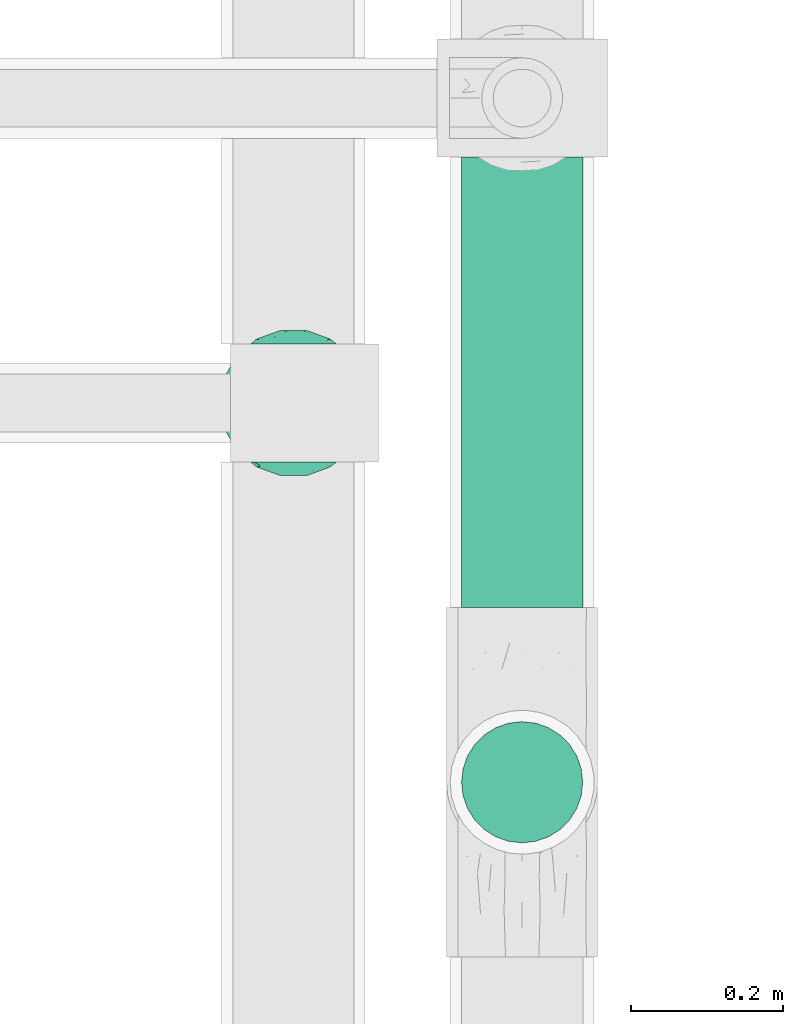
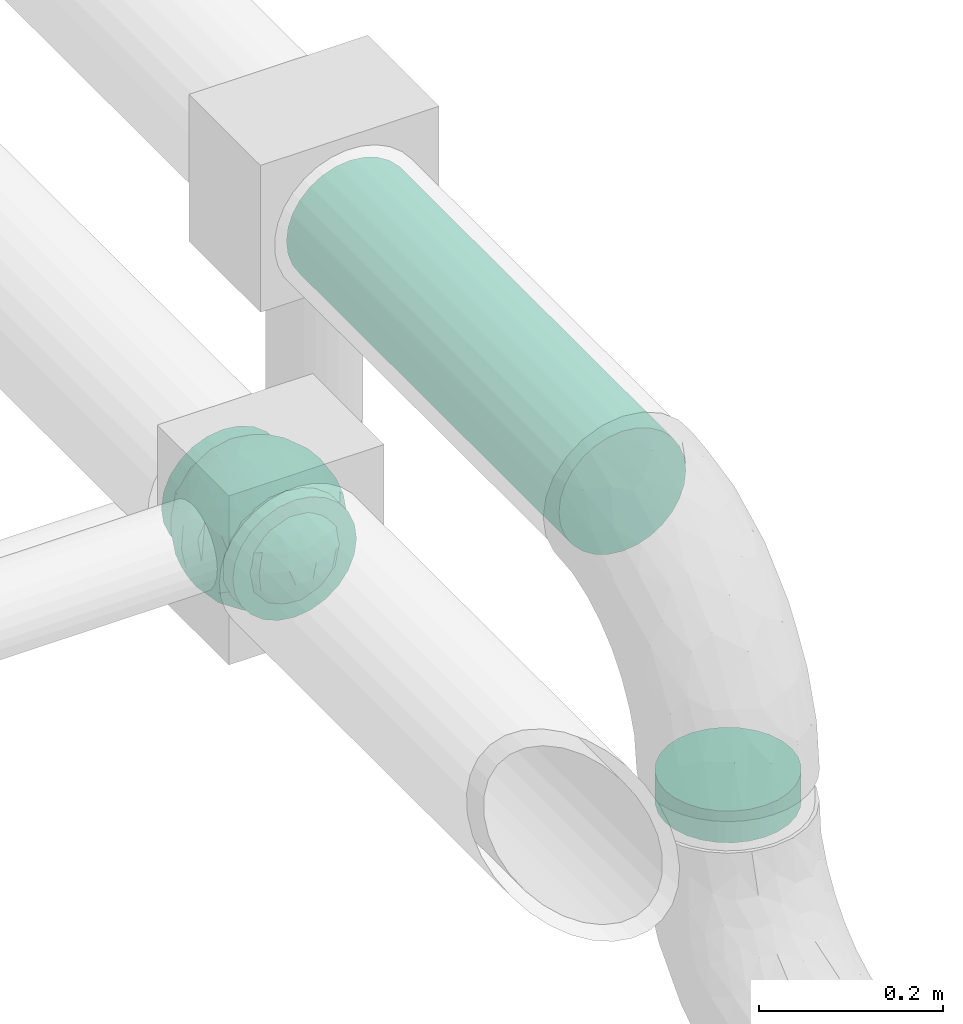
# One storey, part 609 of 827: 2 flow segments, 1 flow fitting.
"""IFC2X3 building model written with IfcOpenShell, lengths in millimetres."""

from ifc_helpers import new_model, entity, si_unit, converted_unit, derived_unit, direction, frame, origin, origin_2d_with_axis, place, context, subcontext, project, spatial, circle, extrude, faceted_brep, source, transform, mapped, material, material_list, type_object, type_shapes, element, save


model = new_model("IFC2X3")

# Units and contexts
model_context = context("Model", 3, precision=0.01, world=origin(), true_north=direction((6.12303176911189e-17, 1.0)))
body_context = subcontext(model_context, "Body", "Model", "MODEL_VIEW")
ifc_project = project(units=[si_unit("LENGTHUNIT", "METRE", prefix="MILLI"), si_unit("AREAUNIT", "SQUARE_METRE"), si_unit("VOLUMEUNIT", "CUBIC_METRE"), converted_unit("PLANEANGLEUNIT", "DEGREE", entity("IfcRatioMeasure", 0.0174532925199433), si_unit("PLANEANGLEUNIT", "RADIAN"), dimensions=[0, 0, 0, 0, 0, 0, 0]), si_unit("MASSUNIT", "GRAM", prefix="KILO"), derived_unit("MASSDENSITYUNIT", [(si_unit("MASSUNIT", "GRAM", prefix="KILO"), 1), (si_unit("LENGTHUNIT", "METRE"), -3)]), derived_unit("MOMENTOFINERTIAUNIT", [(si_unit("LENGTHUNIT", "METRE"), 4)]), si_unit("TIMEUNIT", "SECOND"), si_unit("FREQUENCYUNIT", "HERTZ"), si_unit("THERMODYNAMICTEMPERATUREUNIT", "DEGREE_CELSIUS"), derived_unit("THERMALTRANSMITTANCEUNIT", [(si_unit("MASSUNIT", "GRAM", prefix="KILO"), 1), (si_unit("THERMODYNAMICTEMPERATUREUNIT", "KELVIN"), -1), (si_unit("TIMEUNIT", "SECOND"), -3)]), derived_unit("VOLUMETRICFLOWRATEUNIT", [(si_unit("LENGTHUNIT", "METRE"), 3), (si_unit("TIMEUNIT", "SECOND"), -1)]), derived_unit("MASSFLOWRATEUNIT", [(si_unit("MASSUNIT", "GRAM", prefix="KILO"), 1), (si_unit("TIMEUNIT", "SECOND"), -1)]), derived_unit("ROTATIONALFREQUENCYUNIT", [(si_unit("TIMEUNIT", "SECOND"), -1)]), si_unit("ELECTRICCURRENTUNIT", "AMPERE"), si_unit("ELECTRICVOLTAGEUNIT", "VOLT"), si_unit("POWERUNIT", "WATT"), si_unit("FORCEUNIT", "NEWTON", prefix="KILO"), si_unit("ILLUMINANCEUNIT", "LUX"), si_unit("LUMINOUSFLUXUNIT", "LUMEN"), si_unit("LUMINOUSINTENSITYUNIT", "CANDELA"), derived_unit("USERDEFINED", [(si_unit("MASSUNIT", "GRAM", prefix="KILO"), -1), (si_unit("LENGTHUNIT", "METRE"), -2), (si_unit("TIMEUNIT", "SECOND"), 3), (si_unit("LUMINOUSFLUXUNIT", "LUMEN"), 1)]), derived_unit("LINEARVELOCITYUNIT", [(si_unit("LENGTHUNIT", "METRE"), 1), (si_unit("TIMEUNIT", "SECOND"), -1)]), si_unit("PRESSUREUNIT", "PASCAL"), derived_unit("USERDEFINED", [(si_unit("LENGTHUNIT", "METRE"), -2), (si_unit("MASSUNIT", "GRAM", prefix="KILO"), 1), (si_unit("TIMEUNIT", "SECOND"), -2)]), derived_unit("LINEARFORCEUNIT", [(si_unit("MASSUNIT", "GRAM", prefix="KILO"), 1), (si_unit("LENGTHUNIT", "METRE"), 1), (si_unit("TIMEUNIT", "SECOND"), -2), (si_unit("LENGTHUNIT", "METRE"), -1)]), derived_unit("PLANARFORCEUNIT", [(si_unit("MASSUNIT", "GRAM", prefix="KILO"), 1), (si_unit("LENGTHUNIT", "METRE"), 1), (si_unit("TIMEUNIT", "SECOND"), -2), (si_unit("LENGTHUNIT", "METRE"), -2)])], contexts=[model_context])

# Site, building, storey
site_placement = place(None, origin())
site = spatial("IfcSite", under=ifc_project, at=site_placement, CompositionType="ELEMENT")
building_placement = place(site_placement, origin())
building = spatial("IfcBuilding", under=site, at=building_placement, CompositionType="ELEMENT")
storey_placement = place(building_placement, frame((0.0, 0.0, 28200.0)))
storey = spatial("IfcBuildingStorey", under=building, at=storey_placement, Name="08", CompositionType="ELEMENT", Elevation=28200.0)

# Flow segments
pipe_segment_type = type_object("IfcPipeSegmentType", PredefinedType="NOTDEFINED")
flow_segment_1_placement = place(storey_placement, frame((37967.2, 9811.72, 2918.9)))
element("IfcFlowSegment", 1, at=flow_segment_1_placement, inside=storey, type_object=pipe_segment_type, context=body_context, shape_type="SweptSolid", body=[
    extrude(circle(Radius=79.5, at=origin_2d_with_axis()), frame((81.1, 0.0, 81.1), z_axis=(0.0, 1.0, 0.0), x_axis=(-1.0, 0.0, 0.0)), (0.0, 0.0, 1.0), 590.986619555691),
])
flow_segment_2_placement = place(storey_placement, frame((37967.2, 9501.62, 2729.0)))
element("IfcFlowSegment", 2, at=flow_segment_2_placement, inside=storey, type_object=pipe_segment_type, context=body_context, shape_type="SweptSolid", body=[
    extrude(circle(Radius=79.5, at=origin_2d_with_axis()), frame((81.1, 81.1, 0.0)), (0.0, 0.0, 1.0), 42.0000000000208),
])

# Flow fitting
ifc_material_1 = material()
ifc_material_2 = material(Name="ADSK_")
ifc_material_list = material_list([ifc_material_1, ifc_material_2])
pipe_fitting_type = type_object("IfcPipeFittingType", Name="ADSK_1", PredefinedType="NOTDEFINED", material=ifc_material_list)
shared_shape = source(origin(), body_context, "Body", "Brep", [
    faceted_brep([(-77.5, 38.75, -67.12), (-77.5, 20.06, -74.86), (-77.5, 0.0, -77.5), (-77.5, -20.06, -74.86), (-77.5, -38.75, -67.12), (-77.5, -54.8, -54.8), (-77.5, -67.12, -38.75), (-77.5, -74.86, -20.06), (-77.5, -76.18, -10.03), (-77.5, -77.5, 0.0), (-77.5, -76.18, 10.03), (-77.5, -74.86, 20.06), (-77.5, -67.12, 38.75), (-77.5, -54.8, 54.8), (-77.5, -38.75, 67.12), (-77.5, -20.06, 74.86), (-77.5, 0.0, 77.5), (-77.5, 20.06, 74.86), (-77.5, 38.75, 67.12), (-77.5, 54.8, 54.8), (-77.5, 67.12, 38.75), (-77.5, 74.86, 20.06), (-77.5, 77.5, 0.0), (-77.5, 74.86, -20.06), (-77.5, 67.12, -38.75), (-77.5, 54.8, -54.8), (77.5, 0.0, -77.5), (77.5, 20.06, -74.86), (77.5, 38.75, -67.12), (77.5, 54.8, -54.8), (77.5, 67.12, -38.75), (77.5, 74.86, -20.06), (77.5, 77.5, 0.0), (77.5, 74.86, 20.06), (77.5, 67.12, 38.75), (77.5, 54.8, 54.8), (77.5, 38.75, 67.12), (77.5, 20.06, 74.86), (77.5, 0.0, 77.5), (77.5, -20.06, 74.86), (77.5, -38.75, 67.12), (77.5, -54.8, 54.8), (77.5, -67.12, 38.75), (77.5, -74.86, 20.06), (77.5, -76.18, 10.03), (77.5, -77.5, 0.0), (77.5, -76.18, -10.03), (77.5, -74.86, -20.06), (77.5, -67.12, -38.75), (77.5, -54.8, -54.8), (77.5, -38.75, -67.12), (77.5, -20.06, -74.86), (32.85, -76.55, 12.09), (35.0, -77.5, 0.0), (-35.0, -77.5, 0.0), (26.77, -74.15, 22.55), (6.15, -69.42, 34.46), (17.58, -71.35, 30.26), (11.87, -70.38, 32.36), (-32.85, -76.55, 12.09), (-33.92, -77.03, 6.04), (-26.78, -74.15, 22.54), (-17.59, -71.35, 30.26), (-11.87, -70.38, 32.36), (-6.16, -69.42, 34.45), (0.0, -69.42, 34.45), (33.92, -77.03, 6.04), (6.15, -69.42, -34.46), (-32.85, -76.55, -12.09), (-33.92, -77.03, -6.04), (17.58, -71.35, -30.26), (11.87, -70.38, -32.36), (32.85, -76.55, -12.09), (26.77, -74.15, -22.55), (33.92, -77.03, -6.04), (-6.16, -69.42, -34.45), (-11.87, -70.38, -32.36), (-17.59, -71.35, -30.26), (0.0, -69.42, -34.45), (-26.78, -74.15, -22.54), (0.0, -82.5, -35.0), (9.06, -82.5, -33.81), (17.5, -82.5, -30.31), (24.75, -82.5, -24.75), (30.31, -82.5, -17.5), (33.81, -82.5, -9.06), (35.0, -82.5, 0.0), (33.81, -82.5, 9.06), (30.31, -82.5, 17.5), (24.75, -82.5, 24.75), (17.5, -82.5, 30.31), (9.06, -82.5, 33.81), (0.0, -82.5, 35.0), (-9.06, -82.5, 33.81), (-17.5, -82.5, 30.31), (-24.75, -82.5, 24.75), (-30.31, -82.5, 17.5), (-33.81, -82.5, 9.06), (-35.0, -82.5, 0.0), (-33.81, -82.5, -9.06), (-30.31, -82.5, -17.5), (-24.75, -82.5, -24.75), (-17.5, -82.5, -30.31), (-9.06, -82.5, -33.81)], [[[0, 1, 2, 3, 4, 5, 6, 7, 8, 9, 10, 11, 12, 13, 14, 15, 16, 17, 18, 19, 20, 21, 22, 23, 24, 25]], [[26, 27, 28, 29, 30, 31, 32, 33, 34, 35, 36, 37, 38, 39, 40, 41, 42, 43, 44, 45, 46, 47, 48, 49, 50, 51]], [[44, 43, 52]], [[53, 45, 44]], [[9, 54, 10]], [[43, 55, 52]], [[42, 41, 56]], [[55, 43, 57]], [[42, 56, 58, 57]], [[41, 13, 56]], [[57, 43, 42]], [[59, 11, 10]], [[10, 54, 60, 59]], [[59, 61, 11]], [[12, 62, 63, 64]], [[12, 11, 62]], [[12, 64, 13]], [[62, 11, 61]], [[13, 64, 65, 56]], [[44, 52, 66, 53]], [[41, 40, 14, 13]], [[16, 15, 39, 38]], [[15, 14, 40, 39]], [[17, 16, 38, 37]], [[34, 33, 21, 20]], [[19, 18, 36, 35]], [[20, 19, 35, 34]], [[37, 36, 18, 17]], [[22, 21, 33, 32]], [[24, 23, 31, 30]], [[23, 22, 32, 31]], [[25, 24, 30, 29]], [[26, 51, 3, 2]], [[1, 0, 28, 27]], [[2, 1, 27, 26]], [[29, 28, 0, 25]], [[4, 3, 51, 50]], [[50, 49, 5, 4]], [[49, 48, 67]], [[8, 68, 69, 54]], [[48, 70, 71, 67]], [[48, 47, 70]], [[49, 67, 5]], [[45, 53, 46]], [[8, 54, 9]], [[72, 73, 47]], [[46, 53, 74, 72]], [[47, 73, 70]], [[6, 75, 76, 77]], [[72, 47, 46]], [[6, 5, 75]], [[77, 7, 6]], [[5, 67, 78, 75]], [[79, 68, 7]], [[68, 8, 7]], [[79, 7, 77]], [[80, 81, 82, 83, 84, 85, 86, 87, 88, 89, 90, 91, 92, 93, 94, 95, 96, 97, 98, 99, 100, 101, 102, 103]], [[98, 97, 60]], [[61, 96, 95]], [[97, 96, 59]], [[95, 94, 62]], [[86, 66, 87]], [[98, 60, 54]], [[59, 96, 61]], [[93, 64, 63]], [[63, 62, 94]], [[62, 61, 95]], [[92, 56, 65, 64]], [[93, 63, 94]], [[58, 56, 91]], [[56, 92, 91]], [[92, 64, 93]], [[55, 89, 88]], [[90, 89, 57]], [[52, 88, 87]], [[90, 58, 91]], [[89, 55, 57]], [[58, 90, 57]], [[87, 66, 52]], [[52, 55, 88]], [[97, 59, 60]], [[66, 86, 53]], [[86, 85, 74]], [[73, 84, 83]], [[85, 84, 72]], [[83, 82, 70]], [[98, 69, 99]], [[86, 74, 53]], [[72, 84, 73]], [[81, 67, 71]], [[71, 70, 82]], [[70, 73, 83]], [[80, 75, 78, 67]], [[81, 71, 82]], [[76, 75, 103]], [[75, 80, 103]], [[80, 67, 81]], [[79, 101, 100]], [[101, 77, 102]], [[100, 99, 68]], [[102, 76, 103]], [[101, 79, 77]], [[76, 102, 77]], [[99, 69, 68]], [[68, 79, 100]], [[85, 72, 74]], [[69, 98, 54]]]),
    faceted_brep([(74.09, -36.62, -50.54), (86.5, -25.35, -35.5), (82.61, -45.18, -22.81), (-16.75, -33.7, -89.27), (0.0, -42.78, -86.92), (-23.87, -49.97, -79.49), (73.94, -14.61, -60.86), (53.84, -28.63, -75.28), (-16.57, 93.95, 0.0), (-18.09, 86.11, -40.53), (-32.84, 86.73, -28.0), (-44.04, -10.15, -85.69), (-19.2, 4.88, -94.83), (-22.92, -15.62, -92.82), (89.65, 32.63, 0.0), (82.61, 44.34, -24.37), (83.9, 48.44, 0.0), (47.7, -82.62, 0.0), (60.26, -69.94, -29.38), (62.27, -74.21, 0.0), (95.4, 0.0, 0.0), (95.4, -16.82, 0.0), (94.13, -8.44, -21.26), (93.14, 13.95, -22.71), (95.4, 16.82, 0.0), (76.54, 8.21, -58.81), (74.09, 36.62, -50.54), (84.96, 22.7, -40.64), (28.25, -36.42, -85.21), (19.67, -61.78, -71.98), (-67.45, 51.53, -46.69), (-45.73, 54.97, -65.36), (-59.68, 42.12, -63.64), (47.7, 82.62, 0.0), (62.27, 74.21, 0.0), (59.48, 63.11, -43.18), (-48.12, -74.69, -38.62), (-33.13, -91.03, 0.0), (-47.7, -82.62, 0.0), (72.35, 57.3, -29.46), (60.01, 43.15, -62.62), (62.52, -52.48, -52.18), (45.73, -54.97, -65.36), (-62.27, -74.21, 0.0), (-73.08, -61.32, 0.0), (-72.41, -59.62, -24.21), (7.26, -81.07, -52.53), (35.35, -68.17, -59.06), (27.87, -86.63, -33.22), (-74.09, -36.62, -50.54), (-84.35, -21.79, -42.37), (-76.59, -6.33, -58.98), (61.55, 0.0, -74.81), (-61.55, 0.0, -74.81), (-79.37, 15.54, -53.33), (-95.4, -16.82, 0.0), (-92.58, -16.52, -23.25), (-89.65, -32.63, 0.0), (63.81, 22.67, -69.28), (-18.69, 68.07, -66.35), (-42.94, 76.94, -40.26), (-74.09, 36.62, -50.54), (-43.64, 36.19, -78.55), (-65.1, 21.71, -68.38), (44.46, 15.06, -84.74), (-65.04, -21.76, -68.42), (-94.63, 4.93, -20.13), (-87.93, 0.0, -40.67), (-89.65, 32.63, 0.0), (-89.27, 26.35, -26.85), (27.96, 84.78, -37.61), (7.26, 81.07, -52.53), (1.19, 92.73, -28.0), (3.41, -92.84, -27.46), (-8.28, -95.41, 0.0), (-11.9, -93.14, -23.83), (73.08, 61.32, 0.0), (87.93, 0.0, -40.67), (73.08, -61.32, 0.0), (83.9, -48.44, 0.0), (-73.08, 61.32, 0.0), (-82.24, 45.34, -23.77), (-83.9, 48.44, 0.0), (-63.57, -59.47, -42.5), (-45.73, -54.97, -65.36), (-82.58, -43.28, -26.32), (29.11, 48.1, -78.89), (45.73, 54.97, -65.36), (44.58, 36.0, -78.11), (-61.2, 65.56, -36.61), (-6.93, -65.5, -71.03), (30.56, -5.14, -91.79), (9.54, -19.86, -94.34), (0.0, 12.89, -96.01), (47.81, -10.83, -83.56), (89.65, -32.63, 0.0), (44.95, 76.64, -38.61), (33.13, 91.03, 0.0), (28.53, 69.09, -61.62), (-51.45, 14.65, -80.76), (22.17, 26.71, -90.44), (33.13, -91.03, 0.0), (44.95, -76.64, -38.61), (72.35, -57.3, -29.46), (16.57, -93.95, 0.0), (-15.25, 22.47, -92.99), (2.72, 32.92, -91.07), (8.92, 50.75, -82.03), (9.42, 67.57, -68.78), (16.57, 93.95, 0.0), (-5.45, -87.35, -41.54), (8.28, -95.41, 0.0), (0.0, -96.88, 0.0), (-24.34, -90.45, -24.71), (-25.14, -82.23, -44.62), (-16.57, -93.95, 0.0), (-9.92, -78.26, -56.23), (-30.26, -67.58, -62.46), (-40.87, -32.58, -81.57), (-34.66, 17.97, -88.66), (-59.69, -42.16, -63.59), (-16.8, 39.61, -86.8), (-28.19, 53.95, -75.36), (-10.32, 55.25, -78.9), (-57.91, -73.21, -25.92), (-83.9, -48.44, 0.0), (-95.4, 0.0, 0.0), (-95.4, 16.82, 0.0), (-72.43, 58.81, -26.08), (-62.27, 74.21, 0.0), (-47.7, 82.62, 0.0), (-33.13, 91.03, 0.0), (0.0, 96.87, 0.0), (-74.09, -36.62, 50.54), (-86.5, -25.35, 35.5), (-82.61, -45.18, 22.81), (16.75, -33.7, 89.27), (0.0, -42.78, 86.92), (23.87, -49.97, 79.49), (-73.94, -14.61, 60.86), (-53.84, -28.63, 75.28), (18.09, 86.11, 40.53), (32.84, 86.73, 28.0), (44.04, -10.15, 85.69), (19.2, 4.88, 94.83), (22.92, -15.62, 92.82), (-82.61, 44.34, 24.37), (-60.26, -69.94, 29.38), (-94.13, -8.44, 21.26), (-93.14, 13.95, 22.71), (-76.54, 8.21, 58.81), (-74.09, 36.62, 50.54), (-84.96, 22.7, 40.64), (-28.25, -36.42, 85.21), (-19.67, -61.78, 71.98), (67.45, 51.53, 46.69), (45.73, 54.97, 65.36), (59.68, 42.12, 63.64), (-28.53, 69.09, 61.62), (-45.73, 54.97, 65.36), (-29.11, 48.1, 78.89), (48.12, -74.69, 38.62), (-59.48, 63.11, 43.18), (-72.35, 57.3, 29.46), (-60.01, 43.15, 62.62), (-35.35, -68.17, 59.06), (-7.26, -81.07, 52.53), (72.41, -59.62, 24.21), (-3.41, -92.84, 27.46), (74.09, -36.62, 50.54), (84.35, -21.79, 42.37), (76.59, -6.33, 58.98), (-61.55, 0.0, 74.81), (61.55, 0.0, 74.81), (79.37, 15.54, 53.33), (92.58, -16.52, 23.25), (-63.81, 22.67, 69.28), (18.69, 68.07, 66.35), (42.94, 76.94, 40.26), (74.09, 36.62, 50.54), (43.64, 36.19, 78.55), (65.1, 21.71, 68.38), (-44.46, 15.06, 84.74), (65.04, -21.76, 68.42), (94.63, 4.93, 20.13), (87.93, 0.0, 40.67), (89.27, 26.35, 26.85), (-27.96, 84.78, 37.61), (-7.26, 81.07, 52.53), (-1.19, 92.73, 28.0), (11.9, -93.14, 23.83), (-87.93, 0.0, 40.67), (82.24, 45.34, 23.77), (63.57, -59.47, 42.5), (45.73, -54.97, 65.36), (82.58, -43.28, 26.32), (-44.58, 36.0, 78.11), (61.2, 65.56, 36.61), (25.14, -82.23, 44.62), (5.45, -87.35, 41.54), (24.34, -90.45, 24.71), (6.93, -65.5, 71.03), (-30.56, -5.14, 91.79), (-9.54, -19.86, 94.34), (0.0, 12.89, 96.01), (-47.81, -10.83, 83.56), (-44.95, 76.64, 38.61), (51.45, 14.65, 80.76), (-62.52, -52.48, 52.18), (-45.73, -54.97, 65.36), (-22.17, 26.71, 90.44), (-44.95, -76.64, 38.61), (-72.35, -57.3, 29.46), (-27.87, -86.63, 33.22), (15.25, 22.47, 92.99), (-2.72, 32.92, 91.07), (-8.92, 50.75, 82.03), (-9.42, 67.57, 68.78), (9.92, -78.26, 56.23), (30.26, -67.58, 62.46), (40.87, -32.58, 81.57), (34.66, 17.97, 88.66), (59.69, -42.16, 63.59), (16.8, 39.61, 86.8), (28.19, 53.95, 75.36), (10.32, 55.25, 78.9), (57.91, -73.21, 25.92), (72.43, 58.81, 26.08)], [[[0, 1, 2]], [[3, 4, 5]], [[6, 0, 7]], [[8, 9, 10]], [[11, 12, 13]], [[14, 15, 16]], [[17, 18, 19]], [[20, 21, 22]], [[23, 24, 20]], [[25, 26, 27]], [[4, 28, 29]], [[30, 31, 32]], [[33, 34, 35]], [[36, 37, 38]], [[35, 39, 40]], [[41, 18, 42]], [[43, 44, 45]], [[46, 47, 48]], [[49, 50, 51]], [[52, 25, 6]], [[53, 51, 54]], [[55, 56, 57]], [[26, 25, 58]], [[59, 31, 60]], [[32, 61, 30]], [[62, 63, 32]], [[52, 64, 58]], [[51, 65, 49]], [[56, 66, 67]], [[66, 68, 69]], [[70, 71, 72]], [[73, 74, 75]], [[6, 7, 52]], [[20, 22, 23]], [[76, 39, 34]], [[15, 26, 39]], [[1, 77, 22]], [[78, 2, 79]], [[61, 54, 69]], [[80, 81, 82]], [[36, 83, 84]], [[85, 56, 50]], [[86, 87, 88]], [[60, 31, 89]], [[48, 73, 46]], [[4, 29, 90]], [[91, 92, 93]], [[7, 94, 52]], [[77, 23, 22]], [[95, 79, 2]], [[0, 6, 1]], [[1, 22, 95]], [[1, 95, 2]], [[27, 23, 77]], [[15, 14, 23]], [[25, 27, 77]], [[15, 76, 16]], [[40, 39, 26]], [[39, 76, 15]], [[96, 97, 33]], [[70, 98, 71]], [[39, 35, 34]], [[87, 86, 98]], [[77, 1, 6]], [[25, 52, 58]], [[62, 99, 63]], [[26, 15, 27]], [[6, 25, 77]], [[0, 41, 7]], [[42, 28, 7]], [[92, 91, 28]], [[94, 28, 91]], [[88, 87, 40]], [[52, 94, 64]], [[40, 26, 58]], [[100, 91, 93]], [[88, 40, 58]], [[22, 21, 95]], [[101, 102, 17]], [[103, 78, 19]], [[41, 0, 103]], [[18, 102, 42]], [[101, 48, 102]], [[101, 104, 48]], [[29, 28, 42]], [[28, 4, 92]], [[102, 47, 42]], [[90, 29, 46]], [[88, 58, 64]], [[40, 87, 35]], [[87, 96, 35]], [[33, 35, 96]], [[100, 64, 91]], [[88, 64, 100]], [[12, 105, 93]], [[98, 96, 87]], [[106, 100, 93]], [[86, 100, 107]], [[100, 86, 88]], [[98, 108, 71]], [[108, 86, 107]], [[109, 70, 72]], [[70, 109, 97]], [[96, 98, 70]], [[97, 96, 70]], [[78, 103, 2]], [[0, 2, 103]], [[41, 103, 18]], [[7, 41, 42]], [[19, 18, 103]], [[102, 18, 17]], [[75, 110, 73]], [[73, 104, 111, 112]], [[113, 114, 110]], [[115, 75, 74]], [[36, 114, 37]], [[90, 5, 4]], [[73, 48, 104]], [[47, 46, 29]], [[46, 116, 90]], [[5, 117, 84]], [[90, 116, 117]], [[118, 13, 3]], [[118, 5, 84]], [[11, 119, 12]], [[65, 120, 49]], [[11, 13, 118]], [[63, 53, 54]], [[121, 122, 123]], [[90, 117, 5]], [[49, 120, 83]], [[117, 36, 84]], [[36, 117, 114]], [[43, 45, 124]], [[38, 124, 36]], [[83, 124, 45]], [[85, 125, 57]], [[125, 85, 44]], [[45, 49, 83]], [[66, 55, 126, 127]], [[57, 56, 85]], [[56, 67, 50]], [[51, 50, 67]], [[85, 50, 49]], [[54, 51, 67]], [[51, 53, 65]], [[69, 54, 67]], [[54, 61, 63]], [[69, 67, 66]], [[128, 129, 89]], [[11, 65, 53]], [[120, 118, 84]], [[32, 63, 61]], [[99, 53, 63]], [[118, 120, 65]], [[83, 120, 84]], [[129, 128, 80]], [[62, 32, 31]], [[60, 130, 131]], [[130, 60, 89]], [[9, 71, 59]], [[10, 60, 131]], [[108, 59, 71]], [[71, 9, 72]], [[62, 121, 119]], [[122, 59, 123]], [[62, 119, 99]], [[62, 31, 122]], [[106, 107, 100]], [[44, 85, 45]], [[49, 45, 85]], [[55, 66, 56]], [[62, 122, 121]], [[89, 129, 130]], [[65, 11, 118]], [[11, 53, 99]], [[80, 128, 81]], [[30, 128, 89]], [[81, 61, 69]], [[61, 81, 128]], [[82, 81, 69]], [[10, 59, 60]], [[72, 8, 132]], [[8, 72, 9]], [[109, 72, 132]], [[3, 92, 4]], [[92, 13, 12]], [[23, 27, 15]], [[14, 24, 23]], [[11, 99, 119]], [[128, 30, 61]], [[31, 30, 89]], [[28, 94, 7]], [[64, 94, 91]], [[48, 47, 102]], [[29, 42, 47]], [[105, 106, 93]], [[123, 106, 121]], [[86, 108, 98]], [[108, 107, 123]], [[73, 112, 74]], [[113, 75, 115]], [[114, 116, 110]], [[115, 37, 113]], [[37, 114, 113]], [[46, 73, 110]], [[117, 116, 114]], [[110, 75, 113]], [[46, 110, 116]], [[118, 3, 5]], [[92, 3, 13]], [[105, 119, 121]], [[92, 12, 93]], [[119, 105, 12]], [[106, 105, 121]], [[43, 124, 38]], [[83, 36, 124]], [[68, 66, 127]], [[68, 82, 69]], [[31, 59, 122]], [[108, 123, 59]], [[106, 123, 107]], [[8, 10, 131]], [[59, 10, 9]], [[133, 134, 135]], [[136, 137, 138]], [[139, 133, 140]], [[109, 141, 142]], [[143, 144, 145]], [[68, 146, 82]], [[38, 147, 43]], [[148, 126, 55]], [[149, 127, 126]], [[150, 151, 152]], [[137, 153, 154]], [[155, 156, 157]], [[158, 159, 160]], [[161, 101, 17]], [[162, 163, 164]], [[154, 165, 166]], [[19, 78, 167]], [[168, 115, 74, 112]], [[169, 170, 171]], [[172, 150, 139]], [[173, 171, 174]], [[21, 175, 95]], [[151, 150, 176]], [[177, 156, 178]], [[157, 179, 155]], [[180, 181, 157]], [[172, 182, 176]], [[171, 183, 169]], [[175, 184, 185]], [[186, 24, 14, 16]], [[187, 188, 189]], [[168, 111, 190]], [[139, 140, 172]], [[126, 148, 149]], [[80, 163, 129]], [[146, 151, 163]], [[134, 191, 148]], [[44, 135, 125]], [[179, 174, 186]], [[76, 192, 16]], [[161, 193, 194]], [[195, 175, 170]], [[160, 159, 196]], [[178, 156, 197]], [[198, 199, 200]], [[137, 154, 201]], [[202, 203, 204]], [[140, 205, 172]], [[134, 133, 139]], [[125, 135, 57]], [[148, 191, 149]], [[134, 148, 57]], [[134, 57, 135]], [[152, 149, 191]], [[146, 68, 149]], [[150, 152, 191]], [[146, 80, 82]], [[164, 163, 151]], [[163, 80, 146]], [[162, 130, 129]], [[130, 206, 131]], [[163, 162, 129]], [[158, 188, 187]], [[191, 134, 139]], [[150, 172, 176]], [[180, 207, 181]], [[151, 146, 152]], [[139, 150, 191]], [[133, 208, 140]], [[209, 153, 140]], [[203, 202, 153]], [[205, 153, 202]], [[196, 159, 164]], [[172, 205, 182]], [[164, 151, 176]], [[210, 202, 204]], [[196, 164, 176]], [[148, 55, 57]], [[38, 37, 211]], [[212, 44, 43]], [[208, 133, 212]], [[147, 211, 209]], [[165, 213, 166]], [[209, 208, 147]], [[154, 153, 209]], [[153, 137, 203]], [[211, 165, 209]], [[201, 154, 166]], [[196, 176, 182]], [[164, 159, 162]], [[159, 206, 162]], [[130, 162, 206]], [[210, 182, 202]], [[196, 182, 210]], [[144, 214, 204]], [[158, 206, 159]], [[215, 210, 204]], [[160, 210, 216]], [[210, 160, 196]], [[158, 217, 188]], [[217, 160, 216]], [[8, 187, 189]], [[187, 8, 131]], [[206, 158, 187]], [[131, 206, 187]], [[44, 212, 135]], [[133, 135, 212]], [[208, 212, 147]], [[140, 208, 209]], [[43, 147, 212]], [[211, 147, 38]], [[199, 168, 190]], [[213, 115, 168]], [[213, 168, 166]], [[104, 190, 111]], [[161, 198, 101]], [[201, 138, 137]], [[37, 115, 213]], [[211, 37, 213]], [[166, 218, 201]], [[138, 219, 194]], [[201, 218, 219]], [[220, 145, 136]], [[220, 138, 194]], [[143, 221, 144]], [[183, 222, 169]], [[143, 145, 220]], [[181, 173, 174]], [[223, 224, 225]], [[201, 219, 138]], [[169, 222, 193]], [[219, 161, 194]], [[161, 219, 198]], [[19, 167, 226]], [[17, 226, 161]], [[193, 226, 167]], [[195, 79, 95]], [[79, 195, 78]], [[167, 169, 193]], [[184, 21, 20, 24]], [[95, 175, 195]], [[175, 185, 170]], [[171, 170, 185]], [[195, 170, 169]], [[174, 171, 185]], [[171, 173, 183]], [[186, 174, 185]], [[174, 179, 181]], [[186, 185, 184]], [[227, 34, 197]], [[143, 183, 173]], [[222, 220, 194]], [[157, 181, 179]], [[207, 173, 181]], [[220, 222, 183]], [[193, 222, 194]], [[34, 227, 76]], [[180, 157, 156]], [[178, 33, 97]], [[33, 178, 197]], [[141, 188, 177]], [[142, 178, 97]], [[217, 177, 188]], [[188, 141, 189]], [[180, 223, 221]], [[224, 177, 225]], [[180, 221, 207]], [[180, 156, 224]], [[215, 216, 210]], [[78, 195, 167]], [[169, 167, 195]], [[21, 184, 175]], [[186, 184, 24]], [[197, 34, 33]], [[183, 143, 220]], [[143, 173, 207]], [[76, 227, 192]], [[155, 227, 197]], [[192, 179, 186]], [[179, 192, 227]], [[16, 192, 186]], [[142, 177, 178]], [[189, 109, 132]], [[109, 189, 141]], [[8, 189, 132]], [[136, 203, 137]], [[203, 145, 144]], [[149, 152, 146]], [[68, 127, 149]], [[143, 207, 221]], [[227, 155, 179]], [[156, 155, 197]], [[153, 205, 140]], [[182, 205, 202]], [[213, 165, 211]], [[154, 209, 165]], [[214, 215, 204]], [[225, 215, 223]], [[160, 217, 158]], [[217, 216, 225]], [[168, 112, 111]], [[200, 190, 104]], [[198, 218, 199]], [[104, 101, 200]], [[101, 198, 200]], [[166, 168, 199]], [[219, 218, 198]], [[199, 190, 200]], [[166, 199, 218]], [[220, 136, 138]], [[203, 136, 145]], [[214, 221, 223]], [[203, 144, 204]], [[221, 214, 144]], [[215, 214, 223]], [[19, 226, 17]], [[193, 161, 226]], [[180, 224, 223]], [[156, 177, 224]], [[217, 225, 177]], [[215, 225, 216]], [[109, 142, 97]], [[177, 142, 141]]]),
])
type_shapes(pipe_fitting_type, [shared_shape])
flow_fitting_placement = place(storey_placement, frame((37748.3, 10080.2, 2899.91), z_axis=(0.0, 7.18992413019044e-07, 1.0), x_axis=(0.0, -1.0, 7.18992413019044e-07)))
element("IfcFlowFitting", 3, at=flow_fitting_placement, inside=storey, type_object=pipe_fitting_type, material=ifc_material_list, Name="ADSK_1", ObjectType="ADSK_1", context=body_context, shape_type="MappedRepresentation", body=[
    mapped(shared_shape, transform((0.0, 0.0, 0.0), scale=1.0)),
])

save(model, "model.ifc")
